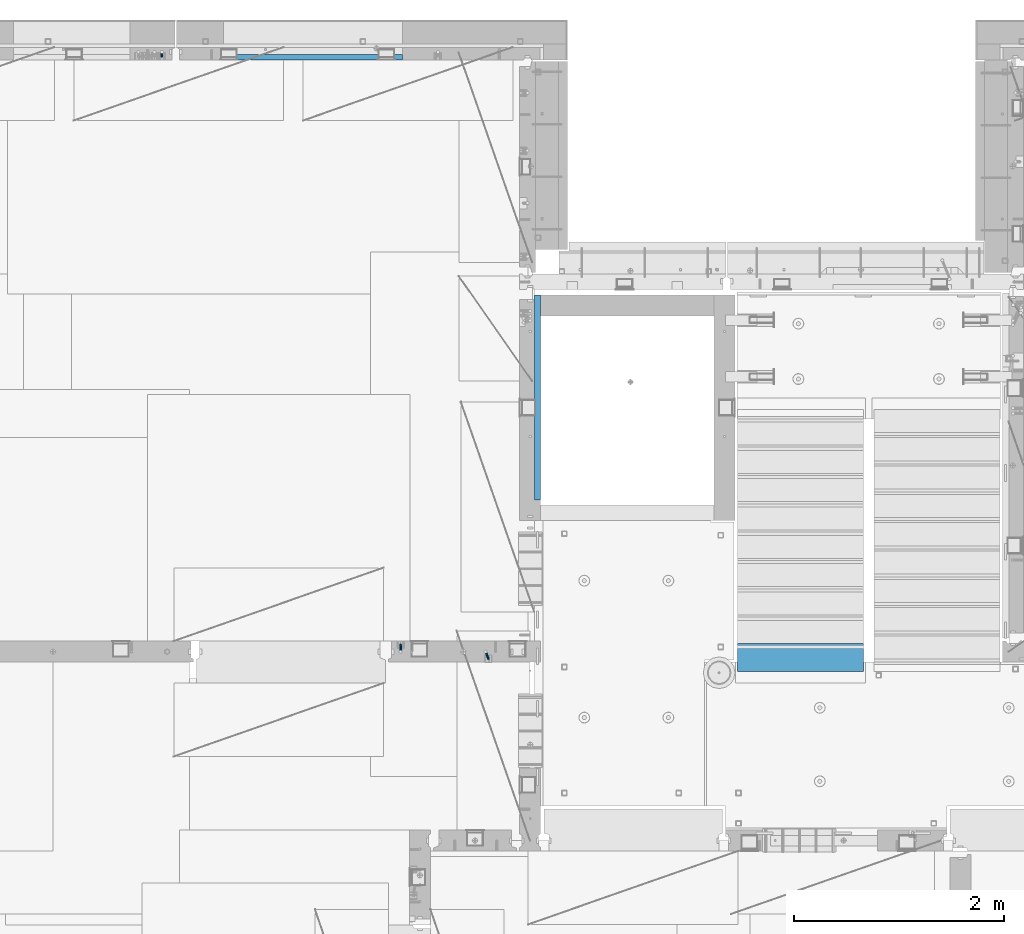
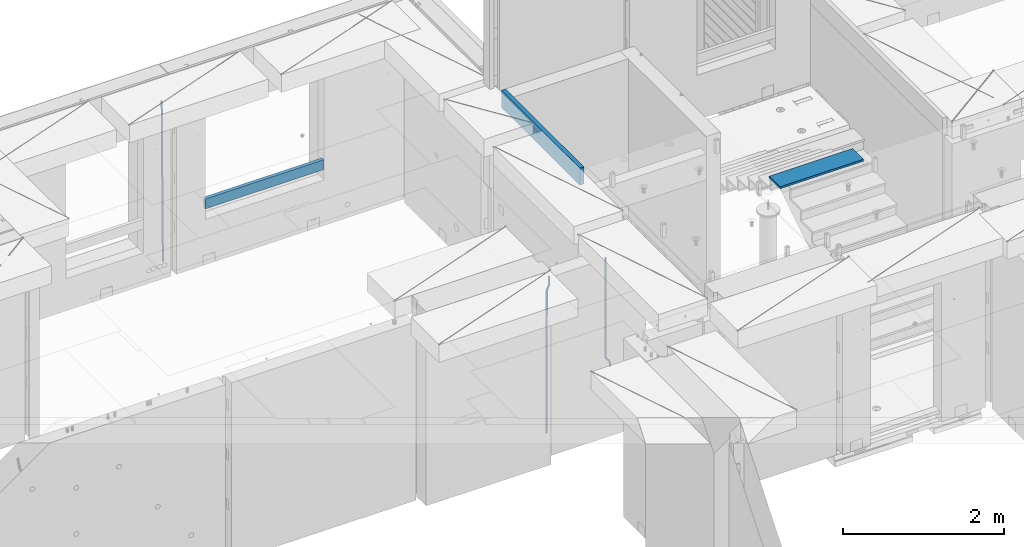
# One storey, part 117 of 352: 6 beams, 5 elements without a shape of their own.
"""IFC2X3 building model written with IfcOpenShell, lengths in millimetres."""

from ifc_helpers import new_model, si_unit, frame, origin_with_axes, place, context, subcontext, project, spatial, faceted_brep, material, type_object, element, aggregate, save


model = new_model("IFC2X3")

# Units and contexts
model_context = context("Model", 3, precision=1e-05, world=origin_with_axes())
body_context = subcontext(model_context, "Body", "Model", "MODEL_VIEW")
ifc_project = project(units=[si_unit("LENGTHUNIT", "METRE", prefix="MILLI"), si_unit("AREAUNIT", "SQUARE_METRE"), si_unit("VOLUMEUNIT", "CUBIC_METRE"), si_unit("MASSUNIT", "GRAM", prefix="KILO"), si_unit("TIMEUNIT", "SECOND"), si_unit("PLANEANGLEUNIT", "RADIAN"), si_unit("SOLIDANGLEUNIT", "STERADIAN"), si_unit("THERMODYNAMICTEMPERATUREUNIT", "DEGREE_CELSIUS"), si_unit("LUMINOUSINTENSITYUNIT", "LUMEN")], contexts=[model_context])

# Site, building, storey
site_placement = place(None, origin_with_axes())
site = spatial("IfcSite", under=ifc_project, at=site_placement, CompositionType="ELEMENT")
building_placement = place(site_placement, origin_with_axes())
building = spatial("IfcBuilding", under=site, at=building_placement, CompositionType="ELEMENT")
storey_placement = place(building_placement, origin_with_axes())
storey = spatial("IfcBuildingStorey", under=building, at=storey_placement, Name="6", CompositionType="ELEMENT", Elevation=0.0)

# Assembly, beams
assembly_1_placement = place(storey_placement, origin_with_axes())
assembly_1 = element("IfcElementAssembly", 1, at=assembly_1_placement, inside=storey, AssemblyPlace="NOTDEFINED", PredefinedType="REINFORCEMENT_UNIT")
ifc_material_1 = material()
beam_type_1 = type_object("IfcBeamType", Name="D20", PredefinedType="NOTDEFINED")
beam_1_placement = place(assembly_1_placement, frame((17285.016478657, 16980.0, 99407.5), z_axis=(-0.000415599999849952, -0.999999913638316, 0.0), x_axis=(-6.05680000062309e-05, -4.00000390151988e-09, -0.999999998165759)))
beam_1 = element("IfcBeam", 2, at=beam_1_placement, type_object=beam_type_1, material=ifc_material_1, Name="JM20", ObjectType="D20", context=body_context, shape_type="Brep", body=[
    faceted_brep([(0.000459931368823163, -9.99999998942076, 0.0), (0.000325058383168653, -7.07106780439426, -7.07106781187031), (1498.53016917036, -7.00214571310062, -7.07110244258729), (1498.53030404639, -9.93107788867201, -3.46394881489687e-05), (0.0, 0.0, -10.0), (1498.52984388257, 0.0689220912790915, -10.0000346307206), (-0.000325382832670584, 7.07106780437971, -7.07106781186667), (1498.52951872915, 7.13998989566971, -7.07110244258365), (-0.000459931412478909, 9.9999999894244, 0.0), (1498.52938418057, 10.0689220807144, -3.46307206200436e-05), (-0.000325058426824398, 7.07106780439062, 7.07106781186667), (1498.52951905355, 7.13998989568427, 7.07103318114605), (0.0, 0.0, 10.0), (1498.52984434133, 0.0689220913009194, 9.99996536927938), (0.000325382789014839, -7.07106780437607, 7.07106781186303), (1498.53016949476, -7.00214571308607, 7.07103318114241), (1512.41720874803, -5.73582294623338, -3.78448857876356), (1509.77427058959, -8.90577003658836, 2.66104918808924), (1506.12781116656, -6.30933666407145, 8.86914963737581), (1503.61387695429, 0.5325217154641, 11.203191722434), (1503.70509651935, 7.6119372551475, 8.29592524499458), (1506.34803467779, 10.7818843455061, 1.85038747814542), (1509.99449410092, 8.18545097300375, -4.35771297110477), (1512.50842831319, 1.34359259344637, -6.6917550561775), (1523.10793428493, 4.85819958866705, 2.43339327473223), (1522.94729923509, -2.24423288682374, 5.28089974098111), (1518.68801206884, 11.068066365151, 3.12656423834051), (1512.27666307625, 12.7477117054659, 6.95436248228361), (1507.62956859401, 8.91322214926913, 11.6745157093537), (1507.46893354415, 1.81078967378926, 14.5220221756208), (1511.88885576031, -4.39907710268017, 13.8288512120525), (1518.30020474852, -6.07872245333419, 10.0010529750907), (1556.47190306216, 16.2553988912259, 53.3150705600565), (1551.82480858495, 12.4209093455574, 58.0352237797015), (1556.63253811194, 23.3578313666767, 50.4675640938258), (1552.2126158958, 29.5676981431861, 51.1607350575687), (1545.80126690332, 31.2473434836029, 54.9885333017664), (1541.1541724212, 27.4128539274789, 59.7086865290003), (1540.99353737144, 20.3104214520208, 62.5561929952273), (1545.41345958759, 14.100554675515, 61.8630220314881), (1560.39637396604, 17.5567067062075, 56.6936612143036), (1557.75345399432, 14.386777545431, 63.1392152562548), (1554.10697584673, 16.9832211248868, 69.3473004384578), (1551.59299696748, 23.8250760096525, 71.6813046576062), (1551.6841720884, 30.9044764000282, 68.7739998967481), (1554.32709206025, 34.0744055607975, 62.3284458548405), (1557.97357020773, 31.4779619813417, 56.1203606726085), (1560.48754908697, 24.6361070965759, 53.7863564534418), (1565.57152260729, 25.0997628321384, 54.9895678972971), (1565.57195097132, 18.0287166318594, 57.9185522284643), (1565.57109441068, 32.1708522292429, 57.9184479422765), (1565.5709172132, 35.0998365550477, 64.9894941556158), (1565.57109481466, 32.1709565155361, 72.0605835657152), (1565.57152317863, 25.0999103152426, 74.9895678968714), (1565.5719513753, 18.0288209181526, 72.0606878518956), (1565.57212857006, 15.0998365824271, 64.9896416479532), (1617.49891294041, 18.0318617339399, 57.9185507229813), (1617.49909054188, 15.1029816944028, 64.9896401330443), (1617.49848457637, 25.1029079342443, 54.989566391796), (1617.49805637961, 32.1739973313524, 57.9184464367172), (1617.49787918197, 35.1029816571718, 64.9894926500019), (1617.49805678344, 32.1741016176347, 72.0605820600649), (1617.49848514747, 25.1030554173267, 74.9895663912539), (1617.49891334424, 18.0319660202294, 72.060686346329)], [[[0, 1, 2, 3]], [[1, 4, 5, 2]], [[4, 6, 7, 5]], [[6, 8, 9, 7]], [[8, 10, 11, 9]], [[10, 12, 13, 11]], [[12, 14, 15, 13]], [[14, 0, 3, 15]], [[14, 12, 10, 8, 6, 4, 1, 0]], [[3, 2, 16, 17]], [[15, 3, 17, 18]], [[13, 15, 18, 19]], [[11, 13, 19, 20]], [[9, 11, 20, 21]], [[7, 9, 21, 22]], [[5, 7, 22, 23]], [[2, 5, 23, 16]], [[23, 24, 25, 16]], [[22, 26, 24, 23]], [[21, 27, 26, 22]], [[20, 28, 27, 21]], [[19, 29, 28, 20]], [[18, 30, 29, 19]], [[17, 31, 30, 18]], [[16, 25, 31, 17]], [[31, 25, 32, 33]], [[25, 24, 34, 32]], [[24, 26, 35, 34]], [[26, 27, 36, 35]], [[27, 28, 37, 36]], [[28, 29, 38, 37]], [[29, 30, 39, 38]], [[30, 31, 33, 39]], [[33, 32, 40, 41]], [[39, 33, 41, 42]], [[38, 39, 42, 43]], [[37, 38, 43, 44]], [[36, 37, 44, 45]], [[35, 36, 45, 46]], [[34, 35, 46, 47]], [[32, 34, 47, 40]], [[47, 48, 49, 40]], [[46, 50, 48, 47]], [[45, 51, 50, 46]], [[44, 52, 51, 45]], [[43, 53, 52, 44]], [[42, 54, 53, 43]], [[41, 55, 54, 42]], [[40, 49, 55, 41]], [[55, 49, 56, 57]], [[49, 48, 58, 56]], [[48, 50, 59, 58]], [[50, 51, 60, 59]], [[51, 52, 61, 60]], [[52, 53, 62, 61]], [[53, 54, 63, 62]], [[54, 55, 57, 63]], [[58, 59, 60, 61, 62, 63, 57, 56]]]),
])
beam_2_placement = place(assembly_1_placement, frame((16475.016478657, 16980.0, 99407.5), z_axis=(-0.000415599999849952, -0.999999913638316, 0.0), x_axis=(-6.05680000062309e-05, -4.00000390151988e-09, -0.999999998165759)))
beam_2 = element("IfcBeam", 3, at=beam_2_placement, type_object=beam_type_1, material=ifc_material_1, Name="JM20", ObjectType="D20", context=body_context, shape_type="Brep", body=[
    faceted_brep([(-0.00060564729210455, -9.99999998165731, 0.0), (-0.000428079845733009, -7.07106779890455, -7.07106781186667), (109.663992146438, -7.07770969181365, -7.07106505070624), (109.663814574931, -10.0066418742208, 2.76014907285571e-06), (0.0, 0.0, -10.0), (109.664420484245, -0.00664189292001538, -9.99999723883957), (0.00042843479604926, 7.07106779888636, -7.07106781186303), (109.66484867355, 7.0644259059809, -7.07106505070988), (0.00060564729210455, 9.99999998166459, 3.63797880709171e-12), (109.665025886861, 9.99335808875549, 2.76115679298528e-06), (0.000428079845733009, 7.07106779890819, 7.07106781186667), (109.664848315049, 7.06442590600273, 7.07107057301982), (0.0, 0.0, 10.0), (109.664419977242, -0.00664189288727357, 10.0000027611604), (-0.000428434810601175, -7.07106779888272, 7.07106781186667), (109.663991787937, -7.07770969179182, 7.07107057302346), (123.019465653822, -0.00769783093346632, 8.49481275451399), (122.368218641306, 7.06342149385819, 5.63932810477127), (120.794596020874, 9.9924781119953, -1.25436342694593), (119.220404581531, 7.06367038153257, -8.14803083615698), (118.567784318744, -0.00734585062309634, -11.0034572490222), (119.219031331319, -7.07846517541839, -8.14797259927946), (120.79265395175, -10.0075217935628, -1.25428106757317), (122.366845391021, -7.07871406308914, 5.63938634164515), (134.432358609134, -7.0801380724879, 1.41616492140383), (135.704448506891, -0.00919495208290755, 4.05476198080942), (131.363125973905, -10.0087693538771, -4.95420191149606), (128.294665451453, -7.07953630984775, -11.3246640276848), (127.024439601548, -0.00834393120385357, -13.9634911148387), (128.296529499246, 7.06259918918295, -11.3248940553931), (131.365762135116, 9.99123047017565, -4.95452722118716), (134.434222657001, 7.06199742654644, 1.41593489364823), (232.333181448281, -7.09406463311461, -61.4435769522424), (235.401641971155, -10.0232976755033, -55.0731148385494), (231.062955598129, -0.0228722546671634, -64.0824040398293), (232.335045495653, 7.04807086590154, -61.4438069808093), (235.404278131435, 9.97670214732716, -55.0734401467271), (238.472738653494, 7.0474691041527, -48.7029780316807), (239.742964503646, -0.0237232742911146, -46.0641509440975), (238.470874606137, -7.09466639485981, -48.7027480031138), (248.152386176487, -0.0244396446978499, -49.0133708264948), (247.497266945589, 7.04670033489674, -51.8679184167595), (245.915123067214, 9.97580676374491, -58.7596380886316), (244.332752967632, 7.04704882145597, -65.6514539264135), (243.677087590491, -0.0239468102772662, -68.5062336817027), (244.33220682136, -7.09508678989368, -65.651686091438), (245.914350699837, -10.0241932187346, -58.7599664195659), (247.496720799376, -7.09543527645292, -51.8681505817658), (256.999396693936, -7.09531210125351, -52.9566469665442), (257.006072236094, -0.0243248818260327, -50.0275278254703), (256.982439129002, -10.0240497531304, -60.0277750206151), (256.965133057005, -7.09492303985826, -67.0987410777925), (256.957616135987, -0.0237746659149707, -70.0274691179584), (256.964291678203, 7.04721255350523, -67.0983499769027), (256.981249241362, 9.97595020465087, -60.027221921624), (256.998555315135, 7.04682349210998, -52.9562558656398), (2308.84129044529, -6.97271028710384, -72.0700484847293), (2308.85859651901, -9.9018369995174, -64.9990824287343), (2308.83377352433, 0.0984380867485015, -74.9987765249425), (2308.84044906651, 7.16942530619053, -72.0696573839123), (2308.85740662973, 10.0981629574344, -64.9985293286554), (2308.87471270347, 7.16903624502447, -57.9275632726531), (2308.88222962443, 0.0978878711684956, -54.9988352324472), (2308.87555408225, -6.9730993482699, -57.9279543734738), (2309.36197244871, -6.97267927451685, -72.0713099986351), (2309.37071429225, -9.90180649703325, -65.000323193126), (2309.3579998037, 0.0984693104364851, -75.0000466259553), (2309.3611234788, 7.16945631832277, -72.0709188794244), (2309.36951366749, 10.0981934592819, -64.9997700670392), (2309.37825551104, 7.16906623676914, -57.9287832615337), (2309.38222815606, 0.0979176518158056, -55.0000466342135), (2309.37910448095, -6.97306935607776, -57.929174380748), (2309.8826559803, -6.97264773775169, -72.0713100117428), (2309.88283356852, -9.90177547898566, -65.0003232060189), (2309.88222762165, 0.0985010618751403, -75.0000466391502), (2309.88179941924, 7.16948785463319, -72.0709188925321), (2309.88162220824, 10.0982244766819, -64.9997700799322), (2309.88179979647, 7.16909673544797, -57.9287832742084), (2309.88222815514, 0.0979479358211393, -55.0000466468009), (2309.88265635754, -6.97303885693691, -57.9291743934191), (2417.50042500655, -6.96612954309967, -72.0713127206036), (2417.50060259478, -9.89525728433364, -65.0003259148798), (2417.49999664789, 0.105019256523519, -75.0000493480147), (2417.49956844548, 7.17600604928157, -72.0709216013965), (2417.49939123449, 10.1047426713303, -64.9997727887931), (2417.49956882271, 7.17561493009634, -57.9287859830729), (2417.49999718138, 0.104466130473156, -55.0000493556618), (2417.50042538378, -6.96652066228489, -57.9291771022799)], [[[0, 1, 2, 3]], [[1, 4, 5, 2]], [[4, 6, 7, 5]], [[6, 8, 9, 7]], [[8, 10, 11, 9]], [[10, 12, 13, 11]], [[12, 14, 15, 13]], [[14, 0, 3, 15]], [[14, 12, 10, 8, 6, 4, 1, 0]], [[11, 13, 16, 17]], [[9, 11, 17, 18]], [[7, 9, 18, 19]], [[5, 7, 19, 20]], [[2, 5, 20, 21]], [[3, 2, 21, 22]], [[15, 3, 22, 23]], [[13, 15, 23, 16]], [[23, 24, 25, 16]], [[22, 26, 24, 23]], [[21, 27, 26, 22]], [[20, 28, 27, 21]], [[19, 29, 28, 20]], [[18, 30, 29, 19]], [[17, 31, 30, 18]], [[16, 25, 31, 17]], [[26, 27, 32, 33]], [[27, 28, 34, 32]], [[28, 29, 35, 34]], [[29, 30, 36, 35]], [[30, 31, 37, 36]], [[31, 25, 38, 37]], [[25, 24, 39, 38]], [[24, 26, 33, 39]], [[37, 38, 40, 41]], [[36, 37, 41, 42]], [[35, 36, 42, 43]], [[34, 35, 43, 44]], [[32, 34, 44, 45]], [[33, 32, 45, 46]], [[39, 33, 46, 47]], [[38, 39, 47, 40]], [[47, 48, 49, 40]], [[46, 50, 48, 47]], [[45, 51, 50, 46]], [[44, 52, 51, 45]], [[43, 53, 52, 44]], [[42, 54, 53, 43]], [[41, 55, 54, 42]], [[40, 49, 55, 41]], [[50, 51, 56, 57]], [[51, 52, 58, 56]], [[52, 53, 59, 58]], [[53, 54, 60, 59]], [[54, 55, 61, 60]], [[55, 49, 62, 61]], [[49, 48, 63, 62]], [[48, 50, 57, 63]], [[57, 56, 64, 65]], [[56, 58, 66, 64]], [[58, 59, 67, 66]], [[59, 60, 68, 67]], [[60, 61, 69, 68]], [[61, 62, 70, 69]], [[62, 63, 71, 70]], [[63, 57, 65, 71]], [[65, 64, 72, 73]], [[64, 66, 74, 72]], [[66, 67, 75, 74]], [[67, 68, 76, 75]], [[68, 69, 77, 76]], [[69, 70, 78, 77]], [[70, 71, 79, 78]], [[71, 65, 73, 79]], [[73, 72, 80, 81]], [[72, 74, 82, 80]], [[74, 75, 83, 82]], [[75, 76, 84, 83]], [[76, 77, 85, 84]], [[77, 78, 86, 85]], [[78, 79, 87, 86]], [[79, 73, 81, 87]], [[82, 83, 84, 85, 86, 87, 81, 80]]]),
])
aggregate(assembly_1, [beam_1, beam_2])

# Assembly, beam
assembly_2_placement = place(storey_placement, origin_with_axes())
assembly_2 = element("IfcElementAssembly", 4, at=assembly_2_placement, inside=storey, AssemblyPlace="NOTDEFINED", PredefinedType="REINFORCEMENT_UNIT")
ifc_material_2 = material(Name="CONCRETE/C25/30")
beam_type_2 = type_object("IfcBeamType", Name="260X60", PredefinedType="NOTDEFINED")
beam_3_placement = place(assembly_2_placement, frame((17779.9999105288, 18424.9992663657, 99600.0), z_axis=(0.0, 0.0, 1.0), x_axis=(0.0, 1.0, 0.0)))
beam_3 = element("IfcBeam", 5, at=beam_3_placement, type_object=beam_type_2, material=ifc_material_2, ObjectType="260X60", context=body_context, shape_type="Brep", body=[
    faceted_brep([(0.0, 30.0, -130.0), (0.0, 30.0, 130.0), (1954.9989445891, 30.0, 130.0), (1954.9989445891, 30.0, -130.0), (0.0, -30.0, 130.0), (1954.9989445891, -30.0, 130.0), (0.0, -30.0, -130.0), (1954.9989445891, -30.0, -130.0)], [[[0, 1, 2, 3]], [[1, 4, 5, 2]], [[4, 6, 7, 5]], [[6, 0, 3, 7]], [[5, 7, 3, 2]], [[6, 4, 1, 0]]]),
])
aggregate(assembly_2, [beam_3])

assembly_3_placement = place(storey_placement, origin_with_axes())
assembly_3 = element("IfcElementAssembly", 6, at=assembly_3_placement, inside=storey, AssemblyPlace="NOTDEFINED", PredefinedType="REINFORCEMENT_UNIT")
beam_type_3 = type_object("IfcBeamType", Name="D25", PredefinedType="NOTDEFINED")
beam_4_placement = place(assembly_3_placement, frame((14200.1300000039, 22654.999995444, 96989.68), z_axis=(-0.000205762999925498, 0.999642804629538, -0.0267249099901004), x_axis=(4.30000201928125e-08, 0.0267249099948059, 0.999642825806181)))
beam_4 = element("IfcBeam", 7, at=beam_4_placement, type_object=beam_type_3, material=ifc_material_1, Name="JM25", ObjectType="D25", context=body_context, shape_type="Brep", body=[
    faceted_brep([(-7.41420080885291e-08, -12.5, -3.63797880709171e-12), (-6.42030499875546e-08, -10.8253175473074, -6.25000000000364), (60.3237677085563, -10.8253175348218, -6.24999999383726), (60.3237677118304, -12.4999999875163, 6.16273609921336e-09), (-3.70782800018787e-08, -6.25000000000364, -10.8253175473074), (60.3237677054713, -6.24999998751628, -10.825317541141), (-1.45519152283669e-11, -3.63797880709171e-12, -12.5), (60.3237677033903, 1.24837242765352e-08, -12.4999999938373), (3.70637280866504e-08, 6.25, -10.8253175473074), (60.323767702881, 6.25000001248372, -10.825317541141), (6.42030499875546e-08, 10.8253175473001, -6.25000000000364), (60.3237677040888, 10.8253175597911, -6.24999999383726), (7.41420080885291e-08, 12.4999999999927, 0.0), (60.3237677066645, 12.5000000124837, 6.15909812040627e-09), (6.42176019027829e-08, 10.8253175473001, 6.24999999999636), (60.3237677099241, 10.8253175597893, 6.25000000616274), (3.70928319171071e-08, 6.24999999999636, 10.8253175473037), (60.3237677130091, 6.25000001248554, 10.8253175534701), (1.45519152283669e-11, -3.63797880709171e-12, 12.4999999999964), (60.3237677151046, 1.24837242765352e-08, 12.5000000061627), (-3.7049176171422e-08, -6.25000000000364, 10.8253175473001), (60.3237677156139, -6.24999998751628, 10.8253175534701), (-6.41884980723262e-08, -10.8253175473074, 6.25), (60.3237677144207, -10.82531753482, 6.25000000616274), (61.0758245489851, -10.8253175346654, -6.24999999375723), (60.991802792938, -12.4999999843931, 6.22458173893392e-09), (61.1373109934648, -6.24999998734893, -10.8253175410573), (61.1598041100515, 1.26583472592756e-08, -12.49999999375), (61.1372768863075, 6.25000001265289, -10.8253175410609), (61.0757654736371, 10.8253175599439, -6.24999999376087), (60.9917690322181, 12.5000000156033, 6.22458173893392e-09), (60.907747276171, 10.8253175599111, 6.25000000622094), (60.8462608316913, 6.25000001259286, 10.8253175535247), (60.8237677151046, 1.25892256619409e-08, 12.5000000062173), (60.8462949388486, -6.24999998740714, 10.825317553521), (60.9078063515044, -10.8253175347018, 6.25000000622458), (61.8276096861373, -10.8253134314764, -6.22978616751061), (61.6596309735614, -12.4999963425144, 0.017955953906494), (61.9505603643775, -6.24999554869282, -10.8034510785947), (61.9955384732893, 4.57403257314581e-06, -12.4775289599711), (61.950492164935, 6.25000445112164, -10.8034519952598), (61.827491561271, 10.8253216628109, -6.22978775521551), (61.6594945747056, 12.5000036571128, 0.0179541205834539), (61.4915158621152, 10.8253207460766, 6.26569624199692), (61.3685651839041, 6.25000286329123, 10.8393611530882), (61.3235870749922, 2.74056583293714e-06, 12.5134390344683), (61.3686333833321, -6.24999713652323, 10.8393620697534), (61.491633986996, -10.8253143482107, 6.26569782971274), (146.560019984419, -10.8248509682762, -3.95152056365259), (146.392041271829, -12.4995338793105, 2.29622155776815), (146.682970662645, -6.24953308548902, -8.52518547473665), (146.727948771557, 0.000467037238195189, -10.1992633561131), (146.682902463217, 6.25046691432544, -8.5251863914018), (146.559901859553, 10.8257841260165, -3.95152215136113), (146.391904872988, 12.5004661203184, 2.29621972444511), (146.223926160397, 10.8257832092804, 8.54396184585858), (146.100975482186, 6.25046532649503, 13.1176267569463), (146.05599737326, 0.000465203767817002, 14.7917046383263), (146.1010436816, -6.24953467331943, 13.1176276736078), (146.224044285264, -10.8248518850105, 8.54396343356711), (147.111078313566, -10.8248479606373, -3.93670383375138), (146.994353869159, -12.4995305919347, 2.31241640066946), (147.196513863179, -6.24953028260825, -8.5113774430065), (147.227768131459, 0.000469765214802464, -10.1858243278657), (147.19646656244, 6.25046971732081, -8.51137779775308), (147.110996386313, 10.8257871338483, -3.93670444818781), (146.994259267696, 12.5004694079234, 2.31241569117628), (146.877534823288, 10.8257867766279, 8.56153592559713), (146.792099273691, 6.25046909859884, 13.1362095348559), (146.760845005425, 0.000469050775791402, 14.8106564197114), (146.792146574429, -6.24953090133022, 13.1362098895952), (146.877616750571, -10.8248483178577, 8.56153654003356), (147.662305566744, -10.824846796575, -3.93093035933998), (147.596851102222, -12.4995293196007, 2.31872686942006), (147.710214487655, -6.24952919779389, -8.50599701707324), (147.727740708287, 0.000470821039925795, -10.1805876875078), (147.710188092009, 6.25047080218064, -8.50599715285716), (147.662259848148, 10.8257882979869, -3.93093059453167), (147.596798310929, 12.5004706803447, 2.31872659784494), (147.531343846407, 10.825788157319, 8.56838382660862), (147.483434925496, 6.25047055853611, 13.1434504843382), (147.465908704849, 0.000470539705929696, 14.8180411547801), (147.483461321142, -6.24952944143479, 13.1434506201294), (147.531389565032, -10.8248469372429, 8.56838406180032), (299.377341023079, -10.8245264100169, -2.34188905237897), (299.311886558571, -12.4992089330408, 3.90776817638471), (299.425249944004, -6.24920881123398, -6.9169557101086), (299.442776164637, 0.000791207598012988, -8.59154638054679), (299.425223548358, 6.25079118874055, -6.91695584589979), (299.377295304497, 10.8261086845469, -2.34188928757067), (299.311833767279, 12.5007910669028, 3.90776790480959), (299.246379302756, 10.8261085438789, 10.1574251335696), (299.198470381845, 6.25079094509601, 14.7324917913029), (299.180944161213, 0.000790926264016889, 16.4070824617411), (299.198496777492, -6.24920905487488, 14.7324919270868), (299.246425021367, -10.8245265506848, 10.157425368765), (299.95725460563, -10.824525185375, -2.33581512151068), (299.97179243555, -12.4991882411778, 3.91467976726199), (299.946633883446, -6.24920771019424, -6.91149481024331), (299.942748741494, 0.000792263424955308, -8.58630974019252), (299.946640200433, 6.25079228984941, -6.91149460340603), (299.957265546982, 10.8261099093088, -2.33581476325344), (299.971750386685, 12.5008117588586, 3.91467993563856), (299.98628821662, 10.8261101063945, 10.1651748323675), (299.996908938818, 6.25079263121188, 14.7408545211001), (300.000794080755, 0.000792657594502089, 16.415669451053), (299.996902621817, -6.24920736882996, 14.7408543142628), (299.986277275268, -10.8245249882893, 10.1651744741102), (300.537133734106, -10.8245269960826, -2.3445816610074), (300.631604424707, -12.4992095999223, 3.90470428084518), (300.467986846197, -6.24920933814974, -6.91937655855145), (300.442691613745, 0.000790702320955461, -8.59386781345165), (300.468025873881, 6.25079066179023, -6.91937684622826), (300.537201332045, 10.8261080984212, -2.34458215927589), (300.631682480074, 12.5007903999558, 3.90470370549519), (300.726153170675, 10.8261077961179, 10.1539896473478), (300.795300058599, 6.25079013818504, 14.7287845448955), (300.82059529105, 0.000790097714343574, 16.403275799792), (300.795261030915, -6.24920986175493, 14.7287848325686), (300.726085572751, -10.8245272983859, 10.1539901456163), (2293.32930409742, -10.8307295605009, -32.4713622331001), (2293.42377478865, -12.5054121599169, -26.2220762900724), (2293.26015720774, -6.2554119058077, -37.0461571338565), (2293.23486197284, -0.00541186651753378, -38.7206483931477), (2293.26019623051, 6.24458809413409, -37.0461574303008), (2293.32937168686, 10.8199055340046, -32.4713627465644), (2293.42385283421, 12.4945878399631, -26.2220768829684), (2293.51832352545, 10.8199052405434, -19.972790939948), (2293.58747041514, 6.24458758585388, -15.3979960391844), (2293.61276565003, -0.00541245343265473, -13.7235047798931), (2293.58743139236, -6.25541241408428, -15.3979957427327), (2293.51825593603, -10.8307298539585, -19.9727904264691), (2294.0420846676, -10.8307317859326, -32.4821379598216), (2294.03681932652, -12.5054140739521, -26.2313442200393), (2294.06778164886, -6.2554144273563, -37.0583666982457), (2294.10702478497, -0.00541458957013674, -38.7338336404937), (2294.14929890928, 6.24458531819619, -37.0595987724118), (2294.18327670435, 10.8199028679592, -32.4842719748667), (2294.1998538474, 12.4945854171456, -26.2338083683717), (2294.19458850632, 10.819903129126, -19.9830146285858), (2294.16889152506, 6.24458577054975, -15.4067858901581), (2294.12964838895, -0.0054140672327776, -13.7313189479173), (2294.08737426462, -6.2554139749991, -15.4055538159919), (2294.05339646956, -10.8307315247621, -19.9808806135297), (2294.75482297382, -10.84002603931, -32.4726521173216), (2294.64982751427, -12.513407826169, -26.2231856868602), (2294.87535820232, -6.26594539088183, -37.0476186524102), (2294.97913588268, -0.0167870967634371, -38.7222267036377), (2295.0383488692, 6.23299192477134, -37.0477663960555), (2295.03713108998, 10.8087684320271, -32.4729080168181), (2294.97580884799, 12.4844668051373, -26.2234811741473), (2294.87081338844, 10.8110850182784, -19.9740147436787), (2294.7502781599, 6.23700436985018, -15.3990482086047), (2294.64650047956, -0.0121539242718427, -13.7244401573698), (2294.58728749304, -6.26193294580662, -15.3989004649666), (2294.58850527227, -10.8377094530588, -19.9737588441894), (2316.44667268227, -11.1228921988077, -32.1839550346631), (2316.34167722271, -12.7962739856739, -25.9344886042054), (2316.56720791078, -6.54881155039038, -36.7589215697517), (2316.67098559113, -0.299653256264719, -38.4335296209792), (2316.73019857766, 5.95012576527006, -36.759069313397), (2316.72898079845, 10.5259022725259, -32.1842109341669), (2316.66765855643, 12.2016006456361, -25.9347840914961), (2316.56266309689, 10.5282188587698, -19.6853176610275), (2316.44212786836, 5.95413821035254, -15.1103511259389), (2316.33835018802, -0.295020083769487, -13.4357430747186), (2316.27913720149, -6.54479910530426, -15.1102033823008), (2316.28035498071, -11.1205756125637, -19.685061761531), (2317.13234804722, -11.1318335458927, -32.1748293731798), (2317.04181141085, -12.8054038787741, -25.9251705100723), (2317.2154741603, -6.5572650749491, -36.7502937866229), (2317.26891617525, -0.307450393454928, -38.4255717558117), (2317.27835434731, 5.94297770185585, -36.7517739018112), (2317.24125972588, 10.5192220504723, -32.1773930078925), (2317.16757178486, 12.1950816748285, -25.9281307404563), (2317.0770351485, 10.5215113419545, -19.6784718773561), (2316.99390903539, 5.94694287101083, -15.1030074639057), (2316.94046702047, -0.302871810494253, -13.4277294947169), (2316.9310288484, -6.55329990579412, -15.1015273487101), (2316.96812346982, -11.1295442544142, -19.6759082426288), (2317.81808136747, -11.1298054502913, -32.1659056455355), (2317.74200467508, -12.803315894289, -25.9160547315114), (2317.86379538118, -6.55536082026447, -36.7418676070083), (2317.8668976831, -0.305700748642266, -38.417815303761), (2317.82655701396, 5.94458339541234, -36.7446799039099), (2317.75358262347, 10.5207330230332, -32.1707766866384), (2317.66752794063, 12.1965725370646, -25.9216793252963), (2317.59145124823, 10.5230620930706, -19.6718284112721), (2317.54573723453, 5.94861746304377, -15.0958664497994), (2317.54263493262, -0.301042608574789, -13.4199187530394), (2317.58297560175, -6.55132675263303, -15.0930541529051), (2317.65594999224, -11.1274763802539, -19.6669573701693), (2417.81884292323, -10.831603083323, -30.8687911350135), (2417.74276623082, -12.505113527317, -24.618940220982), (2417.86455693691, -6.25715845329614, -35.4447530964935), (2417.86765923884, -0.00749838167394046, -37.1207007932499), (2417.82731856969, 6.24278576237703, -35.4475653933878), (2417.75434417921, 10.8189353900088, -30.8736621761236), (2417.66828949639, 12.494774904033, -24.6245648147851), (2417.59221280397, 10.8212644600353, -18.3747139007501), (2417.54649879028, 6.2468198300121, -13.79875193927), (2417.54339648837, -0.00284024161010166, -12.1228042425173), (2417.5837371575, -6.25312438566107, -13.795939642383), (2417.65671154798, -10.8292740132893, -18.3698428596399)], [[[0, 1, 2, 3]], [[1, 4, 5, 2]], [[4, 6, 7, 5]], [[6, 8, 9, 7]], [[8, 10, 11, 9]], [[10, 12, 13, 11]], [[12, 14, 15, 13]], [[14, 16, 17, 15]], [[16, 18, 19, 17]], [[18, 20, 21, 19]], [[20, 22, 23, 21]], [[22, 0, 3, 23]], [[22, 20, 18, 16, 14, 12, 10, 8, 6, 4, 1, 0]], [[3, 2, 24, 25]], [[2, 5, 26, 24]], [[5, 7, 27, 26]], [[7, 9, 28, 27]], [[9, 11, 29, 28]], [[11, 13, 30, 29]], [[13, 15, 31, 30]], [[15, 17, 32, 31]], [[17, 19, 33, 32]], [[19, 21, 34, 33]], [[21, 23, 35, 34]], [[23, 3, 25, 35]], [[25, 24, 36, 37]], [[24, 26, 38, 36]], [[26, 27, 39, 38]], [[27, 28, 40, 39]], [[28, 29, 41, 40]], [[29, 30, 42, 41]], [[30, 31, 43, 42]], [[31, 32, 44, 43]], [[32, 33, 45, 44]], [[33, 34, 46, 45]], [[34, 35, 47, 46]], [[35, 25, 37, 47]], [[37, 36, 48, 49]], [[36, 38, 50, 48]], [[38, 39, 51, 50]], [[39, 40, 52, 51]], [[40, 41, 53, 52]], [[41, 42, 54, 53]], [[42, 43, 55, 54]], [[43, 44, 56, 55]], [[44, 45, 57, 56]], [[45, 46, 58, 57]], [[46, 47, 59, 58]], [[47, 37, 49, 59]], [[49, 48, 60, 61]], [[48, 50, 62, 60]], [[50, 51, 63, 62]], [[51, 52, 64, 63]], [[52, 53, 65, 64]], [[53, 54, 66, 65]], [[54, 55, 67, 66]], [[55, 56, 68, 67]], [[56, 57, 69, 68]], [[57, 58, 70, 69]], [[58, 59, 71, 70]], [[59, 49, 61, 71]], [[61, 60, 72, 73]], [[60, 62, 74, 72]], [[62, 63, 75, 74]], [[63, 64, 76, 75]], [[64, 65, 77, 76]], [[65, 66, 78, 77]], [[66, 67, 79, 78]], [[67, 68, 80, 79]], [[68, 69, 81, 80]], [[69, 70, 82, 81]], [[70, 71, 83, 82]], [[71, 61, 73, 83]], [[73, 72, 84, 85]], [[72, 74, 86, 84]], [[74, 75, 87, 86]], [[75, 76, 88, 87]], [[76, 77, 89, 88]], [[77, 78, 90, 89]], [[78, 79, 91, 90]], [[79, 80, 92, 91]], [[80, 81, 93, 92]], [[81, 82, 94, 93]], [[82, 83, 95, 94]], [[83, 73, 85, 95]], [[85, 84, 96, 97]], [[84, 86, 98, 96]], [[86, 87, 99, 98]], [[87, 88, 100, 99]], [[88, 89, 101, 100]], [[89, 90, 102, 101]], [[90, 91, 103, 102]], [[91, 92, 104, 103]], [[92, 93, 105, 104]], [[93, 94, 106, 105]], [[94, 95, 107, 106]], [[95, 85, 97, 107]], [[97, 96, 108, 109]], [[96, 98, 110, 108]], [[98, 99, 111, 110]], [[99, 100, 112, 111]], [[100, 101, 113, 112]], [[101, 102, 114, 113]], [[102, 103, 115, 114]], [[103, 104, 116, 115]], [[104, 105, 117, 116]], [[105, 106, 118, 117]], [[106, 107, 119, 118]], [[107, 97, 109, 119]], [[109, 108, 120, 121]], [[108, 110, 122, 120]], [[110, 111, 123, 122]], [[111, 112, 124, 123]], [[112, 113, 125, 124]], [[113, 114, 126, 125]], [[114, 115, 127, 126]], [[115, 116, 128, 127]], [[116, 117, 129, 128]], [[117, 118, 130, 129]], [[118, 119, 131, 130]], [[119, 109, 121, 131]], [[121, 120, 132, 133]], [[120, 122, 134, 132]], [[122, 123, 135, 134]], [[123, 124, 136, 135]], [[124, 125, 137, 136]], [[125, 126, 138, 137]], [[126, 127, 139, 138]], [[127, 128, 140, 139]], [[128, 129, 141, 140]], [[129, 130, 142, 141]], [[130, 131, 143, 142]], [[131, 121, 133, 143]], [[133, 132, 144, 145]], [[132, 134, 146, 144]], [[134, 135, 147, 146]], [[135, 136, 148, 147]], [[136, 137, 149, 148]], [[137, 138, 150, 149]], [[138, 139, 151, 150]], [[139, 140, 152, 151]], [[140, 141, 153, 152]], [[141, 142, 154, 153]], [[142, 143, 155, 154]], [[143, 133, 145, 155]], [[145, 144, 156, 157]], [[144, 146, 158, 156]], [[146, 147, 159, 158]], [[147, 148, 160, 159]], [[148, 149, 161, 160]], [[149, 150, 162, 161]], [[150, 151, 163, 162]], [[151, 152, 164, 163]], [[152, 153, 165, 164]], [[153, 154, 166, 165]], [[154, 155, 167, 166]], [[155, 145, 157, 167]], [[157, 156, 168, 169]], [[156, 158, 170, 168]], [[158, 159, 171, 170]], [[159, 160, 172, 171]], [[160, 161, 173, 172]], [[161, 162, 174, 173]], [[162, 163, 175, 174]], [[163, 164, 176, 175]], [[164, 165, 177, 176]], [[165, 166, 178, 177]], [[166, 167, 179, 178]], [[167, 157, 169, 179]], [[169, 168, 180, 181]], [[168, 170, 182, 180]], [[170, 171, 183, 182]], [[171, 172, 184, 183]], [[172, 173, 185, 184]], [[173, 174, 186, 185]], [[174, 175, 187, 186]], [[175, 176, 188, 187]], [[176, 177, 189, 188]], [[177, 178, 190, 189]], [[178, 179, 191, 190]], [[179, 169, 181, 191]], [[181, 180, 192, 193]], [[180, 182, 194, 192]], [[182, 183, 195, 194]], [[183, 184, 196, 195]], [[184, 185, 197, 196]], [[185, 186, 198, 197]], [[186, 187, 199, 198]], [[187, 188, 200, 199]], [[188, 189, 201, 200]], [[189, 190, 202, 201]], [[190, 191, 203, 202]], [[191, 181, 193, 203]], [[194, 195, 196, 197, 198, 199, 200, 201, 202, 203, 193, 192]]]),
])
aggregate(assembly_3, [beam_4])

assembly_4_placement = place(storey_placement, origin_with_axes())
assembly_4 = element("IfcElementAssembly", 8, at=assembly_4_placement, inside=storey, AssemblyPlace="NOTDEFINED", PredefinedType="REINFORCEMENT_UNIT")
ifc_material_3 = material(Name="TIMBER/T24")
beam_type_4 = type_object("IfcBeamType", PredefinedType="NOTDEFINED")
beam_5_placement = place(assembly_4_placement, frame((14784.9997107317, 22644.7399977209, 97680.0), z_axis=(0.0, 0.0, 1.0), x_axis=(1.0, 0.0, 0.0)))
beam_5 = element("IfcBeam", 9, at=beam_5_placement, type_object=beam_type_4, material=ifc_material_3, context=body_context, shape_type="Brep", body=[
    faceted_brep([(-3.63797880709171e-12, 24.9999999999964, -75.0), (-3.63797880709171e-12, 24.9999999999964, 75.0), (1710.00028926826, 25.0, 75.0), (1710.00028926826, 25.0, -75.0), (0.0, -25.0000000000073, 75.0), (1710.00028926826, -25.0, 75.0), (0.0, -25.0000000000073, -75.0), (1710.00028926826, -25.0, -75.0)], [[[0, 1, 2, 3]], [[1, 4, 5, 2]], [[4, 6, 7, 5]], [[6, 0, 3, 7]], [[5, 7, 3, 2]], [[6, 4, 1, 0]]]),
])
aggregate(assembly_4, [beam_5])

assembly_5_placement = place(storey_placement, origin_with_axes())
assembly_5 = element("IfcElementAssembly", 10, at=assembly_5_placement, inside=storey, Name="E9", AssemblyPlace="NOTDEFINED", PredefinedType="NOTDEFINED")
ifc_material_4 = material(Name="Undefined/C32/40")
beam_type_5 = type_object("IfcBeamType", PredefinedType="NOTDEFINED")
beam_6_placement = place(assembly_5_placement, frame((20885.0002457424, 16924.9998138874, 99745.3), z_axis=(0.0, 1.0, 0.0), x_axis=(-1.0, 3.00000001838171e-08, 0.0)))
beam_6 = element("IfcBeam", 11, at=beam_6_placement, type_object=beam_type_5, material=ifc_material_4, Name="E9", context=body_context, shape_type="Brep", body=[
    faceted_brep([(0.0, 15.0, -135.0), (0.0, 15.0, 135.0), (1200.0, 15.0, 135.0), (1200.0, 15.0, -135.0), (0.0, -15.0, 135.0), (1200.0, -15.0, 135.0), (0.0, -15.0, -135.0), (1200.0, -15.0, -135.0)], [[[0, 1, 2, 3]], [[1, 4, 5, 2]], [[4, 6, 7, 5]], [[6, 0, 3, 7]], [[5, 7, 3, 2]], [[6, 4, 1, 0]]]),
])
aggregate(assembly_5, [beam_6])

save(model, "model.ifc")
